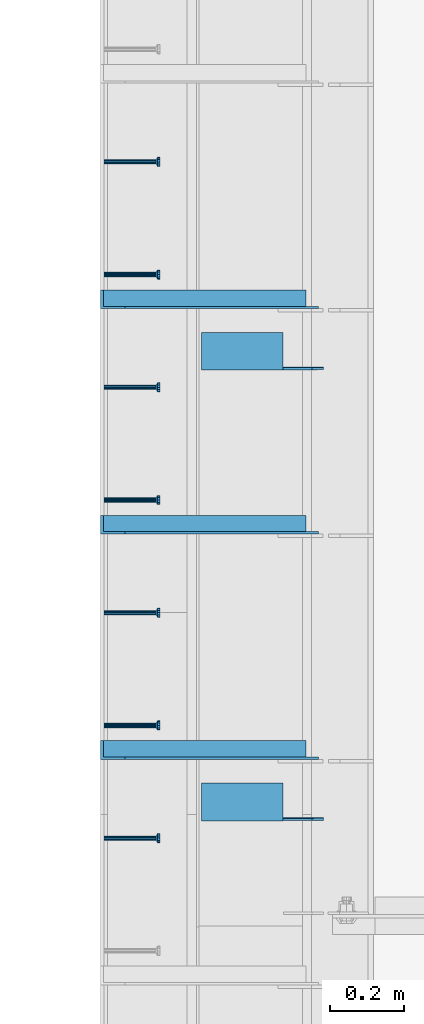
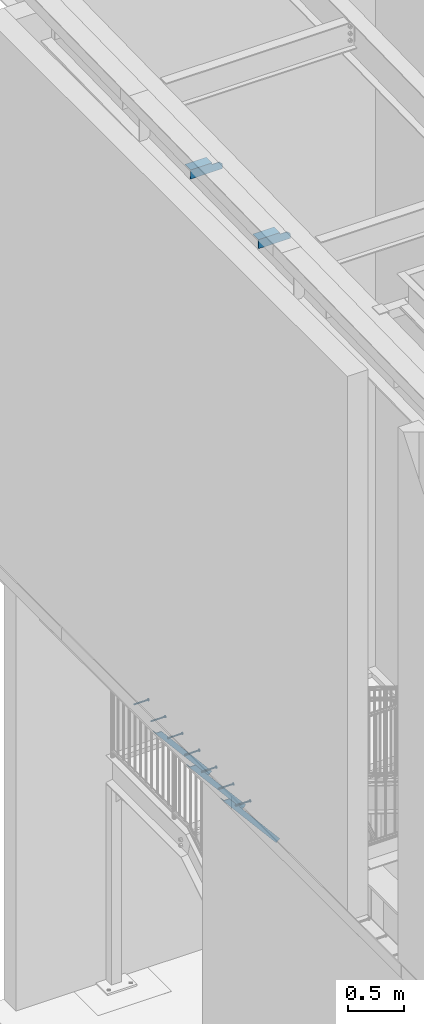
# One storey, part 1265 of 1763: 9 beams, 3 members, 9 elements without a shape of their own.
"""IFC2X3 building model written with IfcOpenShell, lengths in millimetres."""

import ifcopenshell
import ifcopenshell.guid

model = None  # the IFC model being written
_history = None  # IfcOwnerHistory: only IFC2X3 demands one
_inside = {}  # id of a spatial element -> (the spatial element, [elements in it])
_under = {}  # id of a project, library or spatial element -> (it, [spatial elements below it])
_declared = {}  # id of a project -> (the project, [libraries it declares])
_typed = {}  # id of a type object -> (the type object, [elements of that type])
_made_of = {}  # id of a material, layer set ... -> (it, [elements and type objects made of it])


def new_model(schema):
    """Start an empty IFC model of exactly this schema.

    Asked for "IFC4X3", IfcOpenShell would pick the latest addendum, in which some entities
    have other attributes; the version numbers below select the first issue.
    IFC2X3 requires an IfcOwnerHistory on every rooted entity: one is made here for all.
    """
    global model, _history
    if schema == "IFC4X3":
        model = ifcopenshell.file(schema_version=(4, 3, 0, 0))
    else:
        model = ifcopenshell.file(schema=schema)
    _inside.clear()
    _under.clear()
    _declared.clear()
    _typed.clear()
    _made_of.clear()
    _history = None
    if model.schema == "IFC2X3":
        org = make("IfcOrganization", Name="unknown")
        user = make(
            "IfcPersonAndOrganization",
            ThePerson=make("IfcPerson", FamilyName="unknown"),
            TheOrganization=org,
        )
        app = make(
            "IfcApplication",
            ApplicationDeveloper=org,
            Version="unknown",
            ApplicationFullName="unknown",
            ApplicationIdentifier="unknown",
        )
        _history = make(
            "IfcOwnerHistory",
            OwningUser=user,
            OwningApplication=app,
            ChangeAction="ADDED",
            CreationDate=0,
        )
    return model


def make(cls, **values):
    """One entity of the class cls with the attributes given. An attribute that is None is left unset."""
    return model.create_entity(
        cls, **{name: value for name, value in values.items() if value is not None}
    )


def rooted(cls, **values):
    """An entity with a GlobalId (a new one), such as an element, a storey or a relation."""
    return make(cls, GlobalId=ifcopenshell.guid.new(), OwnerHistory=_history, **values)


def si_unit(unit_type, name, prefix=None):
    """IfcSIUnit, for example si_unit("LENGTHUNIT", "METRE", prefix="MILLI")."""
    return make("IfcSIUnit", UnitType=unit_type, Prefix=prefix, Name=name)


def assignment(units):
    """IfcUnitAssignment: the units of a project."""
    return None if units is None else make("IfcUnitAssignment", Units=units)


def point(xyz):
    """IfcCartesianPoint."""
    return None if xyz is None else make("IfcCartesianPoint", Coordinates=xyz)


def direction(xyz):
    """IfcDirection."""
    return None if xyz is None else make("IfcDirection", DirectionRatios=xyz)


def frame(location, z_axis=None, x_axis=None):
    """IfcAxis2Placement3D, a coordinate frame: its origin and axes. An axis left out is left unset."""
    return make(
        "IfcAxis2Placement3D",
        Location=point(location),
        Axis=direction(z_axis),
        RefDirection=direction(x_axis),
    )


def origin_with_axes():
    """The frame at (0, 0, 0) with the z axis (0, 0, 1) and the x axis (1, 0, 0) written out."""
    return frame((0.0, 0.0, 0.0), z_axis=(0.0, 0.0, 1.0), x_axis=(1.0, 0.0, 0.0))


def place(relative_to, where):
    """IfcLocalPlacement: puts the frame where relative to a parent placement (None: the world)."""
    return make(
        "IfcLocalPlacement", PlacementRelTo=relative_to, RelativePlacement=where
    )


def context(
    kind, dimensions, precision=None, world=None, true_north=None, identifier=None
):
    """IfcGeometricRepresentationContext, for example the 3D "Model" context."""
    return make(
        "IfcGeometricRepresentationContext",
        ContextIdentifier=identifier,
        ContextType=kind,
        CoordinateSpaceDimension=dimensions,
        Precision=precision,
        WorldCoordinateSystem=world,
        TrueNorth=true_north,
    )


def subcontext(parent, identifier, kind, view, scale=None):
    """IfcGeometricRepresentationSubContext, for example "Body" below "Model"."""
    return make(
        "IfcGeometricRepresentationSubContext",
        ContextIdentifier=identifier,
        ContextType=kind,
        ParentContext=parent,
        TargetScale=scale,
        TargetView=view,
    )


def project(units=None, contexts=None):
    """IfcProject with its units and contexts."""
    return rooted(
        "IfcProject",
        Name="project",
        RepresentationContexts=contexts,
        UnitsInContext=assignment(units),
    )


def spatial(cls, under=None, at=None, **own):
    """A site, building, storey or space (cls), placed at a placement, below another one or the project."""
    s = rooted(cls, ObjectPlacement=at, **own)
    if under is not None:
        _under.setdefault(under.id(), (under, []))[1].append(s)
    return s


def faces_of(points, faces, orient=None, outer=None):
    """IfcFace entities. A face is a list of loops; a loop is a list of indices into points, from 0.

    orient and outer hold one flag for each loop. By default every Orientation is true, the
    first loop of a face is its IfcFaceOuterBound and the others are IfcFaceBound.
    """
    made = []
    for i, loops in enumerate(faces):
        bounds = []
        for j, loop in enumerate(loops):
            is_outer = j == 0 if outer is None else outer[i][j]
            bounds.append(
                make(
                    "IfcFaceOuterBound" if is_outer else "IfcFaceBound",
                    Bound=make("IfcPolyLoop", Polygon=[points[k] for k in loop]),
                    Orientation=True if orient is None else orient[i][j],
                )
            )
        made.append(make("IfcFace", Bounds=bounds))
    return made


def faceted_brep(points, faces, orient=None, outer=None, voids=None):
    """IfcFacetedBrep: a solid bounded by flat faces; with voids (closed shells), ...WithVoids."""
    shared = [point(p) for p in points]
    hull = make("IfcClosedShell", CfsFaces=faces_of(shared, faces, orient, outer))
    if voids is None:
        return make("IfcFacetedBrep", Outer=hull)
    return make(
        "IfcFacetedBrepWithVoids",
        Outer=hull,
        Voids=[
            make(cls, CfsFaces=faces_of(shared, fs, o, b)) for cls, fs, o, b in voids
        ],
    )


def shape(context_of_items, identifier, shape_type, items):
    """IfcShapeRepresentation: the items that make up one representation, for example the "Body"."""
    return make(
        "IfcShapeRepresentation",
        ContextOfItems=context_of_items,
        RepresentationIdentifier=identifier,
        RepresentationType=shape_type,
        Items=items,
    )


def material(Name=None, Category=None):
    """IfcMaterial."""
    return make("IfcMaterial", Name=Name, Category=Category)


def made_of(thing, what):
    """Note that an element or type object is made of a material, layer set ...; save() writes the relation."""
    if what is not None:
        _made_of.setdefault(what.id(), (what, []))[1].append(thing)
    return thing


def type_object(cls, material=None, **own):
    """A type object (cls), such as IfcWallType, which elements share."""
    return made_of(rooted(cls, **own), material)


def element(
    cls,
    number,
    at=None,
    inside=None,
    cuts=None,
    type_object=None,
    material=None,
    context=None,
    identifier="Body",
    shape_type=None,
    held_by="IfcProductDefinitionShape",
    body=None,
    shapes=None,
    **own,
):
    """One element of the class cls, such as IfcWall. Its Tag is "e" and its number.

    at: its placement. inside: the storey or other place that contains it. cuts: it is an
    opening in that element (IfcRelVoidsElement). A single representation is given by context,
    identifier, shape_type and body (its items); several are given by shapes. held_by: the class
    of the entity that holds the representations. save() writes the other relations.
    """
    e = rooted(cls, Tag="e%d" % number, ObjectPlacement=at, **own)
    if body is not None:
        shapes = [shape(context, identifier, shape_type, body)]
    if shapes is not None:
        e.Representation = make(held_by, Representations=shapes)
    if inside is not None:
        _inside.setdefault(inside.id(), (inside, []))[1].append(e)
    if cuts is not None:
        rooted(
            "IfcRelVoidsElement", RelatingBuildingElement=cuts, RelatedOpeningElement=e
        )
    if type_object is not None:
        _typed.setdefault(type_object.id(), (type_object, []))[1].append(e)
    return made_of(e, material)


def aggregate(whole, parts):
    """IfcRelAggregates: a whole, such as a stair, and the parts it consists of."""
    return rooted("IfcRelAggregates", RelatingObject=whole, RelatedObjects=parts)


def save(model, path):
    """Write the relations noted so far, then the file.

    IfcRelAggregates (storeys below a building ...), IfcRelContainedInSpatialStructure (elements
    in a storey), IfcRelDefinesByType, IfcRelAssociatesMaterial and IfcRelDeclares: one each for
    every whole, place, type object, material and project.
    """
    for whole, parts in _under.values():
        aggregate(whole, parts)
    for where, things in _inside.values():
        rooted(
            "IfcRelContainedInSpatialStructure",
            RelatedElements=things,
            RelatingStructure=where,
        )
    for kind, things in _typed.values():
        rooted("IfcRelDefinesByType", RelatedObjects=things, RelatingType=kind)
    for what, things in _made_of.values():
        rooted("IfcRelAssociatesMaterial", RelatedObjects=things, RelatingMaterial=what)
    for by, libraries in _declared.values():
        rooted("IfcRelDeclares", RelatingContext=by, RelatedDefinitions=libraries)
    model.write(path)


model = new_model("IFC2X3")

# Units and contexts
model_context = context("Model", 3, precision=1e-05, world=origin_with_axes())
body_context = subcontext(model_context, "Body", "Model", "MODEL_VIEW")
ifc_project = project(units=[si_unit("LENGTHUNIT", "METRE", prefix="MILLI"), si_unit("AREAUNIT", "SQUARE_METRE"), si_unit("VOLUMEUNIT", "CUBIC_METRE"), si_unit("MASSUNIT", "GRAM", prefix="KILO"), si_unit("TIMEUNIT", "SECOND"), si_unit("PLANEANGLEUNIT", "RADIAN"), si_unit("SOLIDANGLEUNIT", "STERADIAN"), si_unit("THERMODYNAMICTEMPERATUREUNIT", "DEGREE_CELSIUS"), si_unit("LUMINOUSINTENSITYUNIT", "LUMEN")], contexts=[model_context])

# Site, building, storey
site_placement = place(None, origin_with_axes())
site = spatial("IfcSite", under=ifc_project, at=site_placement, CompositionType="ELEMENT")
building_placement = place(site_placement, origin_with_axes())
building = spatial("IfcBuilding", under=site, at=building_placement, Name="Undefined", CompositionType="ELEMENT")
storey_placement = place(building_placement, origin_with_axes())
storey = spatial("IfcBuildingStorey", under=building, at=storey_placement, Name="Undefined", CompositionType="ELEMENT", Elevation=0.0)

# Assembly, beam
assembly_1_placement = place(storey_placement, origin_with_axes())
assembly_1 = element("IfcElementAssembly", 1, at=assembly_1_placement, inside=storey, Name="HEADED STUD ANCHOR", AssemblyPlace="NOTDEFINED", PredefinedType="RIGID_FRAME")
ifc_material_1 = material(Name="STEEL/A108")
beam_type_1 = type_object("IfcBeamType", PredefinedType="NOTDEFINED")
beam_1_placement = place(assembly_1_placement, frame((-87975.5122736983, 33010.4750061035, 5268.91250001202), z_axis=(0.0, 0.0, -1.0), x_axis=(1.0, 0.0, 0.0)))
beam_1 = element("IfcBeam", 2, at=beam_1_placement, type_object=beam_type_1, material=ifc_material_1, Name="HEADED STUD ANCHOR", context=body_context, shape_type="Brep", body=[
    faceted_brep([(0.0, -3.1800000667572, 5.5), (0.0, -5.5, 3.1800000667572), (141.732000000002, -5.5, 3.1800000667572), (141.732000000002, -3.1800000667572, 5.5), (0.0, -6.34999999999491, 1.45519152283669e-11), (141.732000000002, -6.34999990463257, 0.0), (0.0, -5.5, -3.1800000667572), (141.732000000002, -5.5, -3.1800000667572), (0.0, -3.1800000667572, -5.5), (141.732000000002, -3.1800000667572, -5.5), (0.0, 0.0, -6.34999990463257), (141.732000000002, 0.0, -6.34999990463257), (0.0, 3.1800000667572, -5.5), (141.732000000002, 3.1800000667572, -5.5), (0.0, 5.5, -3.1800000667572), (141.732000000002, 5.5, -3.1800000667572), (0.0, 6.34999999999491, -2.91038304567337e-11), (141.732000000002, 6.34999990463257, 0.0), (0.0, 5.5, 3.1800000667572), (141.732000000002, 5.5, 3.1800000667572), (0.0, 3.1800000667572, 5.5), (141.732000000002, 3.1800000667572, 5.5), (0.0, 0.0, 6.34999990463257), (141.732000000002, 0.0, 6.34999990463257), (144.780000000001, -10.9899997711182, 6.34999990463257), (144.780000000001, -6.34000015258789, 10.9899997711182), (144.780000000001, -12.6999998092651, 0.0), (144.780000000001, -10.9899997711182, -6.34999990463257), (144.780000000001, -6.34000015258789, -10.9899997711182), (144.780000000001, 0.0, -12.6899995803833), (144.780000000001, 6.34000015258789, -10.9899997711182), (144.780000000001, 10.9899997711182, -6.34999990463257), (144.780000000001, 12.6999998092651, 0.0), (144.780000000001, 10.9899997711182, 6.34999990463257), (144.780000000001, 6.34000015258789, 10.9899997711182), (144.780000000001, 0.0, 12.6899995803833), (152.400000000001, -10.9899997711182, 6.34999990463257), (152.400000000001, -6.34000015258789, 10.9899997711182), (152.400000000001, -12.6999998092651, 0.0), (152.400000000001, -10.9899997711182, -6.34999990463257), (152.400000000001, -6.34000015258789, -10.9899997711182), (152.400000000001, 0.0, -12.6899995803833), (152.400000000001, 6.34000015258789, -10.9899997711182), (152.400000000001, 10.9899997711182, -6.34999990463257), (152.400000000001, 12.6999998092651, 0.0), (152.400000000001, 10.9899997711182, 6.34999990463257), (152.400000000001, 6.34000015258789, 10.9899997711182), (152.400000000001, 0.0, 12.6899995803833)], [[[0, 1, 2, 3]], [[1, 4, 5, 2]], [[4, 6, 7, 5]], [[6, 8, 9, 7]], [[8, 10, 11, 9]], [[10, 12, 13, 11]], [[12, 14, 15, 13]], [[14, 16, 17, 15]], [[16, 18, 19, 17]], [[18, 20, 21, 19]], [[20, 22, 23, 21]], [[22, 0, 3, 23]], [[22, 20, 18, 16, 14, 12, 10, 8, 6, 4, 1, 0]], [[3, 2, 24, 25]], [[2, 5, 26, 24]], [[5, 7, 27, 26]], [[7, 9, 28, 27]], [[9, 11, 29, 28]], [[11, 13, 30, 29]], [[13, 15, 31, 30]], [[15, 17, 32, 31]], [[17, 19, 33, 32]], [[19, 21, 34, 33]], [[21, 23, 35, 34]], [[23, 3, 25, 35]], [[25, 24, 36, 37]], [[24, 26, 38, 36]], [[26, 27, 39, 38]], [[27, 28, 40, 39]], [[28, 29, 41, 40]], [[29, 30, 42, 41]], [[30, 31, 43, 42]], [[31, 32, 44, 43]], [[32, 33, 45, 44]], [[33, 34, 46, 45]], [[34, 35, 47, 46]], [[35, 25, 37, 47]], [[38, 39, 40, 41, 42, 43, 44, 45, 46, 47, 37, 36]]]),
])
aggregate(assembly_1, [beam_1])

assembly_2_placement = place(storey_placement, origin_with_axes())
assembly_2 = element("IfcElementAssembly", 3, at=assembly_2_placement, inside=storey, Name="HEADED STUD ANCHOR", AssemblyPlace="NOTDEFINED", PredefinedType="RIGID_FRAME")
beam_2_placement = place(assembly_2_placement, frame((-87975.5122736983, 33315.2750061035, 5268.91250001202), z_axis=(0.0, 0.0, -1.0), x_axis=(1.0, 0.0, 0.0)))
beam_2 = element("IfcBeam", 4, at=beam_2_placement, type_object=beam_type_1, material=ifc_material_1, Name="HEADED STUD ANCHOR", context=body_context, shape_type="Brep", body=[
    faceted_brep([(0.0, -3.1800000667572, 5.5), (0.0, -5.5, 3.1800000667572), (141.732000000002, -5.5, 3.1800000667572), (141.732000000002, -3.1800000667572, 5.5), (0.0, -6.34999999999491, 1.45519152283669e-11), (141.732000000002, -6.34999990463257, 0.0), (0.0, -5.5, -3.1800000667572), (141.732000000002, -5.5, -3.1800000667572), (0.0, -3.1800000667572, -5.5), (141.732000000002, -3.1800000667572, -5.5), (0.0, 0.0, -6.34999990463257), (141.732000000002, 0.0, -6.34999990463257), (0.0, 3.1800000667572, -5.5), (141.732000000002, 3.1800000667572, -5.5), (0.0, 5.5, -3.1800000667572), (141.732000000002, 5.5, -3.1800000667572), (0.0, 6.34999999999491, -2.91038304567337e-11), (141.732000000002, 6.34999990463257, 0.0), (0.0, 5.5, 3.1800000667572), (141.732000000002, 5.5, 3.1800000667572), (0.0, 3.1800000667572, 5.5), (141.732000000002, 3.1800000667572, 5.5), (0.0, 0.0, 6.34999990463257), (141.732000000002, 0.0, 6.34999990463257), (144.780000000001, -10.9899997711182, 6.34999990463257), (144.780000000001, -6.34000015258789, 10.9899997711182), (144.780000000001, -12.6999998092651, 0.0), (144.780000000001, -10.9899997711182, -6.34999990463257), (144.780000000001, -6.34000015258789, -10.9899997711182), (144.780000000001, 0.0, -12.6899995803833), (144.780000000001, 6.34000015258789, -10.9899997711182), (144.780000000001, 10.9899997711182, -6.34999990463257), (144.780000000001, 12.6999998092651, 0.0), (144.780000000001, 10.9899997711182, 6.34999990463257), (144.780000000001, 6.34000015258789, 10.9899997711182), (144.780000000001, 0.0, 12.6899995803833), (152.400000000001, -10.9899997711182, 6.34999990463257), (152.400000000001, -6.34000015258789, 10.9899997711182), (152.400000000001, -12.6999998092651, 0.0), (152.400000000001, -10.9899997711182, -6.34999990463257), (152.400000000001, -6.34000015258789, -10.9899997711182), (152.400000000001, 0.0, -12.6899995803833), (152.400000000001, 6.34000015258789, -10.9899997711182), (152.400000000001, 10.9899997711182, -6.34999990463257), (152.400000000001, 12.6999998092651, 0.0), (152.400000000001, 10.9899997711182, 6.34999990463257), (152.400000000001, 6.34000015258789, 10.9899997711182), (152.400000000001, 0.0, 12.6899995803833)], [[[0, 1, 2, 3]], [[1, 4, 5, 2]], [[4, 6, 7, 5]], [[6, 8, 9, 7]], [[8, 10, 11, 9]], [[10, 12, 13, 11]], [[12, 14, 15, 13]], [[14, 16, 17, 15]], [[16, 18, 19, 17]], [[18, 20, 21, 19]], [[20, 22, 23, 21]], [[22, 0, 3, 23]], [[22, 20, 18, 16, 14, 12, 10, 8, 6, 4, 1, 0]], [[3, 2, 24, 25]], [[2, 5, 26, 24]], [[5, 7, 27, 26]], [[7, 9, 28, 27]], [[9, 11, 29, 28]], [[11, 13, 30, 29]], [[13, 15, 31, 30]], [[15, 17, 32, 31]], [[17, 19, 33, 32]], [[19, 21, 34, 33]], [[21, 23, 35, 34]], [[23, 3, 25, 35]], [[25, 24, 36, 37]], [[24, 26, 38, 36]], [[26, 27, 39, 38]], [[27, 28, 40, 39]], [[28, 29, 41, 40]], [[29, 30, 42, 41]], [[30, 31, 43, 42]], [[31, 32, 44, 43]], [[32, 33, 45, 44]], [[33, 34, 46, 45]], [[34, 35, 47, 46]], [[35, 25, 37, 47]], [[38, 39, 40, 41, 42, 43, 44, 45, 46, 47, 37, 36]]]),
])
aggregate(assembly_2, [beam_2])

assembly_3_placement = place(storey_placement, origin_with_axes())
assembly_3 = element("IfcElementAssembly", 5, at=assembly_3_placement, inside=storey, Name="HEADED STUD ANCHOR", AssemblyPlace="NOTDEFINED", PredefinedType="RIGID_FRAME")
beam_3_placement = place(assembly_3_placement, frame((-87975.5122736983, 33620.0750061035, 5268.91250001202), z_axis=(0.0, 0.0, -1.0), x_axis=(1.0, 0.0, 0.0)))
beam_3 = element("IfcBeam", 6, at=beam_3_placement, type_object=beam_type_1, material=ifc_material_1, Name="HEADED STUD ANCHOR", context=body_context, shape_type="Brep", body=[
    faceted_brep([(0.0, -3.1800000667572, 5.5), (0.0, -5.5, 3.1800000667572), (141.732000000002, -5.5, 3.1800000667572), (141.732000000002, -3.1800000667572, 5.5), (0.0, -6.34999999999491, 1.45519152283669e-11), (141.732000000002, -6.34999990463257, 0.0), (0.0, -5.5, -3.1800000667572), (141.732000000002, -5.5, -3.1800000667572), (0.0, -3.1800000667572, -5.5), (141.732000000002, -3.1800000667572, -5.5), (0.0, 0.0, -6.34999990463257), (141.732000000002, 0.0, -6.34999990463257), (0.0, 3.1800000667572, -5.5), (141.732000000002, 3.1800000667572, -5.5), (0.0, 5.5, -3.1800000667572), (141.732000000002, 5.5, -3.1800000667572), (0.0, 6.34999999999491, -2.91038304567337e-11), (141.732000000002, 6.34999990463257, 0.0), (0.0, 5.5, 3.1800000667572), (141.732000000002, 5.5, 3.1800000667572), (0.0, 3.1800000667572, 5.5), (141.732000000002, 3.1800000667572, 5.5), (0.0, 0.0, 6.34999990463257), (141.732000000002, 0.0, 6.34999990463257), (144.780000000001, -10.9899997711182, 6.34999990463257), (144.780000000001, -6.34000015258789, 10.9899997711182), (144.780000000001, -12.6999998092651, 0.0), (144.780000000001, -10.9899997711182, -6.34999990463257), (144.780000000001, -6.34000015258789, -10.9899997711182), (144.780000000001, 0.0, -12.6899995803833), (144.780000000001, 6.34000015258789, -10.9899997711182), (144.780000000001, 10.9899997711182, -6.34999990463257), (144.780000000001, 12.6999998092651, 0.0), (144.780000000001, 10.9899997711182, 6.34999990463257), (144.780000000001, 6.34000015258789, 10.9899997711182), (144.780000000001, 0.0, 12.6899995803833), (152.400000000001, -10.9899997711182, 6.34999990463257), (152.400000000001, -6.34000015258789, 10.9899997711182), (152.400000000001, -12.6999998092651, 0.0), (152.400000000001, -10.9899997711182, -6.34999990463257), (152.400000000001, -6.34000015258789, -10.9899997711182), (152.400000000001, 0.0, -12.6899995803833), (152.400000000001, 6.34000015258789, -10.9899997711182), (152.400000000001, 10.9899997711182, -6.34999990463257), (152.400000000001, 12.6999998092651, 0.0), (152.400000000001, 10.9899997711182, 6.34999990463257), (152.400000000001, 6.34000015258789, 10.9899997711182), (152.400000000001, 0.0, 12.6899995803833)], [[[0, 1, 2, 3]], [[1, 4, 5, 2]], [[4, 6, 7, 5]], [[6, 8, 9, 7]], [[8, 10, 11, 9]], [[10, 12, 13, 11]], [[12, 14, 15, 13]], [[14, 16, 17, 15]], [[16, 18, 19, 17]], [[18, 20, 21, 19]], [[20, 22, 23, 21]], [[22, 0, 3, 23]], [[22, 20, 18, 16, 14, 12, 10, 8, 6, 4, 1, 0]], [[3, 2, 24, 25]], [[2, 5, 26, 24]], [[5, 7, 27, 26]], [[7, 9, 28, 27]], [[9, 11, 29, 28]], [[11, 13, 30, 29]], [[13, 15, 31, 30]], [[15, 17, 32, 31]], [[17, 19, 33, 32]], [[19, 21, 34, 33]], [[21, 23, 35, 34]], [[23, 3, 25, 35]], [[25, 24, 36, 37]], [[24, 26, 38, 36]], [[26, 27, 39, 38]], [[27, 28, 40, 39]], [[28, 29, 41, 40]], [[29, 30, 42, 41]], [[30, 31, 43, 42]], [[31, 32, 44, 43]], [[32, 33, 45, 44]], [[33, 34, 46, 45]], [[34, 35, 47, 46]], [[35, 25, 37, 47]], [[38, 39, 40, 41, 42, 43, 44, 45, 46, 47, 37, 36]]]),
])
aggregate(assembly_3, [beam_3])

assembly_4_placement = place(storey_placement, origin_with_axes())
assembly_4 = element("IfcElementAssembly", 7, at=assembly_4_placement, inside=storey, Name="HEADED STUD ANCHOR", AssemblyPlace="NOTDEFINED", PredefinedType="RIGID_FRAME")
beam_4_placement = place(assembly_4_placement, frame((-87975.5122736983, 33924.8750061035, 5268.91250001202), z_axis=(0.0, 0.0, -1.0), x_axis=(1.0, 0.0, 0.0)))
beam_4 = element("IfcBeam", 8, at=beam_4_placement, type_object=beam_type_1, material=ifc_material_1, Name="HEADED STUD ANCHOR", context=body_context, shape_type="Brep", body=[
    faceted_brep([(0.0, -3.1800000667572, 5.5), (0.0, -5.5, 3.1800000667572), (141.732000000002, -5.5, 3.1800000667572), (141.732000000002, -3.1800000667572, 5.5), (0.0, -6.34999999999491, 1.45519152283669e-11), (141.732000000002, -6.34999990463257, 0.0), (0.0, -5.5, -3.1800000667572), (141.732000000002, -5.5, -3.1800000667572), (0.0, -3.1800000667572, -5.5), (141.732000000002, -3.1800000667572, -5.5), (0.0, 0.0, -6.34999990463257), (141.732000000002, 0.0, -6.34999990463257), (0.0, 3.1800000667572, -5.5), (141.732000000002, 3.1800000667572, -5.5), (0.0, 5.5, -3.1800000667572), (141.732000000002, 5.5, -3.1800000667572), (0.0, 6.34999999999491, -2.91038304567337e-11), (141.732000000002, 6.34999990463257, 0.0), (0.0, 5.5, 3.1800000667572), (141.732000000002, 5.5, 3.1800000667572), (0.0, 3.1800000667572, 5.5), (141.732000000002, 3.1800000667572, 5.5), (0.0, 0.0, 6.34999990463257), (141.732000000002, 0.0, 6.34999990463257), (144.780000000001, -10.9899997711182, 6.34999990463257), (144.780000000001, -6.34000015258789, 10.9899997711182), (144.780000000001, -12.6999998092651, 0.0), (144.780000000001, -10.9899997711182, -6.34999990463257), (144.780000000001, -6.34000015258789, -10.9899997711182), (144.780000000001, 0.0, -12.6899995803833), (144.780000000001, 6.34000015258789, -10.9899997711182), (144.780000000001, 10.9899997711182, -6.34999990463257), (144.780000000001, 12.6999998092651, 0.0), (144.780000000001, 10.9899997711182, 6.34999990463257), (144.780000000001, 6.34000015258789, 10.9899997711182), (144.780000000001, 0.0, 12.6899995803833), (152.400000000001, -10.9899997711182, 6.34999990463257), (152.400000000001, -6.34000015258789, 10.9899997711182), (152.400000000001, -12.6999998092651, 0.0), (152.400000000001, -10.9899997711182, -6.34999990463257), (152.400000000001, -6.34000015258789, -10.9899997711182), (152.400000000001, 0.0, -12.6899995803833), (152.400000000001, 6.34000015258789, -10.9899997711182), (152.400000000001, 10.9899997711182, -6.34999990463257), (152.400000000001, 12.6999998092651, 0.0), (152.400000000001, 10.9899997711182, 6.34999990463257), (152.400000000001, 6.34000015258789, 10.9899997711182), (152.400000000001, 0.0, 12.6899995803833)], [[[0, 1, 2, 3]], [[1, 4, 5, 2]], [[4, 6, 7, 5]], [[6, 8, 9, 7]], [[8, 10, 11, 9]], [[10, 12, 13, 11]], [[12, 14, 15, 13]], [[14, 16, 17, 15]], [[16, 18, 19, 17]], [[18, 20, 21, 19]], [[20, 22, 23, 21]], [[22, 0, 3, 23]], [[22, 20, 18, 16, 14, 12, 10, 8, 6, 4, 1, 0]], [[3, 2, 24, 25]], [[2, 5, 26, 24]], [[5, 7, 27, 26]], [[7, 9, 28, 27]], [[9, 11, 29, 28]], [[11, 13, 30, 29]], [[13, 15, 31, 30]], [[15, 17, 32, 31]], [[17, 19, 33, 32]], [[19, 21, 34, 33]], [[21, 23, 35, 34]], [[23, 3, 25, 35]], [[25, 24, 36, 37]], [[24, 26, 38, 36]], [[26, 27, 39, 38]], [[27, 28, 40, 39]], [[28, 29, 41, 40]], [[29, 30, 42, 41]], [[30, 31, 43, 42]], [[31, 32, 44, 43]], [[32, 33, 45, 44]], [[33, 34, 46, 45]], [[34, 35, 47, 46]], [[35, 25, 37, 47]], [[38, 39, 40, 41, 42, 43, 44, 45, 46, 47, 37, 36]]]),
])
aggregate(assembly_4, [beam_4])

assembly_5_placement = place(storey_placement, origin_with_axes())
assembly_5 = element("IfcElementAssembly", 9, at=assembly_5_placement, inside=storey, Name="HEADED STUD ANCHOR", AssemblyPlace="NOTDEFINED", PredefinedType="RIGID_FRAME")
beam_5_placement = place(assembly_5_placement, frame((-87975.5122736983, 34229.6750061035, 5268.91250001202), z_axis=(0.0, 0.0, -1.0), x_axis=(1.0, 0.0, 0.0)))
beam_5 = element("IfcBeam", 10, at=beam_5_placement, type_object=beam_type_1, material=ifc_material_1, Name="HEADED STUD ANCHOR", context=body_context, shape_type="Brep", body=[
    faceted_brep([(0.0, -3.1800000667572, 5.5), (0.0, -5.5, 3.1800000667572), (141.732000000002, -5.5, 3.1800000667572), (141.732000000002, -3.1800000667572, 5.5), (0.0, -6.34999999999491, 1.45519152283669e-11), (141.732000000002, -6.34999990463257, 0.0), (0.0, -5.5, -3.1800000667572), (141.732000000002, -5.5, -3.1800000667572), (0.0, -3.1800000667572, -5.5), (141.732000000002, -3.1800000667572, -5.5), (0.0, 0.0, -6.34999990463257), (141.732000000002, 0.0, -6.34999990463257), (0.0, 3.1800000667572, -5.5), (141.732000000002, 3.1800000667572, -5.5), (0.0, 5.5, -3.1800000667572), (141.732000000002, 5.5, -3.1800000667572), (0.0, 6.34999999999491, -2.91038304567337e-11), (141.732000000002, 6.34999990463257, 0.0), (0.0, 5.5, 3.1800000667572), (141.732000000002, 5.5, 3.1800000667572), (0.0, 3.1800000667572, 5.5), (141.732000000002, 3.1800000667572, 5.5), (0.0, 0.0, 6.34999990463257), (141.732000000002, 0.0, 6.34999990463257), (144.780000000001, -10.9899997711182, 6.34999990463257), (144.780000000001, -6.34000015258789, 10.9899997711182), (144.780000000001, -12.6999998092651, 0.0), (144.780000000001, -10.9899997711182, -6.34999990463257), (144.780000000001, -6.34000015258789, -10.9899997711182), (144.780000000001, 0.0, -12.6899995803833), (144.780000000001, 6.34000015258789, -10.9899997711182), (144.780000000001, 10.9899997711182, -6.34999990463257), (144.780000000001, 12.6999998092651, 0.0), (144.780000000001, 10.9899997711182, 6.34999990463257), (144.780000000001, 6.34000015258789, 10.9899997711182), (144.780000000001, 0.0, 12.6899995803833), (152.400000000001, -10.9899997711182, 6.34999990463257), (152.400000000001, -6.34000015258789, 10.9899997711182), (152.400000000001, -12.6999998092651, 0.0), (152.400000000001, -10.9899997711182, -6.34999990463257), (152.400000000001, -6.34000015258789, -10.9899997711182), (152.400000000001, 0.0, -12.6899995803833), (152.400000000001, 6.34000015258789, -10.9899997711182), (152.400000000001, 10.9899997711182, -6.34999990463257), (152.400000000001, 12.6999998092651, 0.0), (152.400000000001, 10.9899997711182, 6.34999990463257), (152.400000000001, 6.34000015258789, 10.9899997711182), (152.400000000001, 0.0, 12.6899995803833)], [[[0, 1, 2, 3]], [[1, 4, 5, 2]], [[4, 6, 7, 5]], [[6, 8, 9, 7]], [[8, 10, 11, 9]], [[10, 12, 13, 11]], [[12, 14, 15, 13]], [[14, 16, 17, 15]], [[16, 18, 19, 17]], [[18, 20, 21, 19]], [[20, 22, 23, 21]], [[22, 0, 3, 23]], [[22, 20, 18, 16, 14, 12, 10, 8, 6, 4, 1, 0]], [[3, 2, 24, 25]], [[2, 5, 26, 24]], [[5, 7, 27, 26]], [[7, 9, 28, 27]], [[9, 11, 29, 28]], [[11, 13, 30, 29]], [[13, 15, 31, 30]], [[15, 17, 32, 31]], [[17, 19, 33, 32]], [[19, 21, 34, 33]], [[21, 23, 35, 34]], [[23, 3, 25, 35]], [[25, 24, 36, 37]], [[24, 26, 38, 36]], [[26, 27, 39, 38]], [[27, 28, 40, 39]], [[28, 29, 41, 40]], [[29, 30, 42, 41]], [[30, 31, 43, 42]], [[31, 32, 44, 43]], [[32, 33, 45, 44]], [[33, 34, 46, 45]], [[34, 35, 47, 46]], [[35, 25, 37, 47]], [[38, 39, 40, 41, 42, 43, 44, 45, 46, 47, 37, 36]]]),
])
aggregate(assembly_5, [beam_5])

assembly_6_placement = place(storey_placement, origin_with_axes())
assembly_6 = element("IfcElementAssembly", 11, at=assembly_6_placement, inside=storey, Name="HEADED STUD ANCHOR", AssemblyPlace="NOTDEFINED", PredefinedType="RIGID_FRAME")
beam_6_placement = place(assembly_6_placement, frame((-87975.5122736983, 34534.4750061035, 5268.91250001202), z_axis=(0.0, 0.0, -1.0), x_axis=(1.0, 0.0, 0.0)))
beam_6 = element("IfcBeam", 12, at=beam_6_placement, type_object=beam_type_1, material=ifc_material_1, Name="HEADED STUD ANCHOR", context=body_context, shape_type="Brep", body=[
    faceted_brep([(0.0, -3.1800000667572, 5.5), (0.0, -5.5, 3.1800000667572), (141.732000000002, -5.5, 3.1800000667572), (141.732000000002, -3.1800000667572, 5.5), (0.0, -6.34999999999491, 1.45519152283669e-11), (141.732000000002, -6.34999990463257, 0.0), (0.0, -5.5, -3.1800000667572), (141.732000000002, -5.5, -3.1800000667572), (0.0, -3.1800000667572, -5.5), (141.732000000002, -3.1800000667572, -5.5), (0.0, 0.0, -6.34999990463257), (141.732000000002, 0.0, -6.34999990463257), (0.0, 3.1800000667572, -5.5), (141.732000000002, 3.1800000667572, -5.5), (0.0, 5.5, -3.1800000667572), (141.732000000002, 5.5, -3.1800000667572), (0.0, 6.34999999999491, -2.91038304567337e-11), (141.732000000002, 6.34999990463257, 0.0), (0.0, 5.5, 3.1800000667572), (141.732000000002, 5.5, 3.1800000667572), (0.0, 3.1800000667572, 5.5), (141.732000000002, 3.1800000667572, 5.5), (0.0, 0.0, 6.34999990463257), (141.732000000002, 0.0, 6.34999990463257), (144.780000000001, -10.9899997711182, 6.34999990463257), (144.780000000001, -6.34000015258789, 10.9899997711182), (144.780000000001, -12.6999998092651, 0.0), (144.780000000001, -10.9899997711182, -6.34999990463257), (144.780000000001, -6.34000015258789, -10.9899997711182), (144.780000000001, 0.0, -12.6899995803833), (144.780000000001, 6.34000015258789, -10.9899997711182), (144.780000000001, 10.9899997711182, -6.34999990463257), (144.780000000001, 12.6999998092651, 0.0), (144.780000000001, 10.9899997711182, 6.34999990463257), (144.780000000001, 6.34000015258789, 10.9899997711182), (144.780000000001, 0.0, 12.6899995803833), (152.400000000001, -10.9899997711182, 6.34999990463257), (152.400000000001, -6.34000015258789, 10.9899997711182), (152.400000000001, -12.6999998092651, 0.0), (152.400000000001, -10.9899997711182, -6.34999990463257), (152.400000000001, -6.34000015258789, -10.9899997711182), (152.400000000001, 0.0, -12.6899995803833), (152.400000000001, 6.34000015258789, -10.9899997711182), (152.400000000001, 10.9899997711182, -6.34999990463257), (152.400000000001, 12.6999998092651, 0.0), (152.400000000001, 10.9899997711182, 6.34999990463257), (152.400000000001, 6.34000015258789, 10.9899997711182), (152.400000000001, 0.0, 12.6899995803833)], [[[0, 1, 2, 3]], [[1, 4, 5, 2]], [[4, 6, 7, 5]], [[6, 8, 9, 7]], [[8, 10, 11, 9]], [[10, 12, 13, 11]], [[12, 14, 15, 13]], [[14, 16, 17, 15]], [[16, 18, 19, 17]], [[18, 20, 21, 19]], [[20, 22, 23, 21]], [[22, 0, 3, 23]], [[22, 20, 18, 16, 14, 12, 10, 8, 6, 4, 1, 0]], [[3, 2, 24, 25]], [[2, 5, 26, 24]], [[5, 7, 27, 26]], [[7, 9, 28, 27]], [[9, 11, 29, 28]], [[11, 13, 30, 29]], [[13, 15, 31, 30]], [[15, 17, 32, 31]], [[17, 19, 33, 32]], [[19, 21, 34, 33]], [[21, 23, 35, 34]], [[23, 3, 25, 35]], [[25, 24, 36, 37]], [[24, 26, 38, 36]], [[26, 27, 39, 38]], [[27, 28, 40, 39]], [[28, 29, 41, 40]], [[29, 30, 42, 41]], [[30, 31, 43, 42]], [[31, 32, 44, 43]], [[32, 33, 45, 44]], [[33, 34, 46, 45]], [[34, 35, 47, 46]], [[35, 25, 37, 47]], [[38, 39, 40, 41, 42, 43, 44, 45, 46, 47, 37, 36]]]),
])
aggregate(assembly_6, [beam_6])

assembly_7_placement = place(storey_placement, origin_with_axes())
assembly_7 = element("IfcElementAssembly", 13, at=assembly_7_placement, inside=storey, Name="HEADED STUD ANCHOR", AssemblyPlace="NOTDEFINED", PredefinedType="RIGID_FRAME")
beam_7_placement = place(assembly_7_placement, frame((-87975.5122736983, 34839.2750061035, 5268.91250001202), z_axis=(0.0, 0.0, -1.0), x_axis=(1.0, 0.0, 0.0)))
beam_7 = element("IfcBeam", 14, at=beam_7_placement, type_object=beam_type_1, material=ifc_material_1, Name="HEADED STUD ANCHOR", context=body_context, shape_type="Brep", body=[
    faceted_brep([(0.0, -3.1800000667572, 5.5), (0.0, -5.5, 3.1800000667572), (141.732000000002, -5.5, 3.1800000667572), (141.732000000002, -3.1800000667572, 5.5), (0.0, -6.34999999999491, 1.45519152283669e-11), (141.732000000002, -6.34999990463257, 0.0), (0.0, -5.5, -3.1800000667572), (141.732000000002, -5.5, -3.1800000667572), (0.0, -3.1800000667572, -5.5), (141.732000000002, -3.1800000667572, -5.5), (0.0, 0.0, -6.34999990463257), (141.732000000002, 0.0, -6.34999990463257), (0.0, 3.1800000667572, -5.5), (141.732000000002, 3.1800000667572, -5.5), (0.0, 5.5, -3.1800000667572), (141.732000000002, 5.5, -3.1800000667572), (0.0, 6.34999999999491, -2.91038304567337e-11), (141.732000000002, 6.34999990463257, 0.0), (0.0, 5.5, 3.1800000667572), (141.732000000002, 5.5, 3.1800000667572), (0.0, 3.1800000667572, 5.5), (141.732000000002, 3.1800000667572, 5.5), (0.0, 0.0, 6.34999990463257), (141.732000000002, 0.0, 6.34999990463257), (144.780000000001, -10.9899997711182, 6.34999990463257), (144.780000000001, -6.34000015258789, 10.9899997711182), (144.780000000001, -12.6999998092651, 0.0), (144.780000000001, -10.9899997711182, -6.34999990463257), (144.780000000001, -6.34000015258789, -10.9899997711182), (144.780000000001, 0.0, -12.6899995803833), (144.780000000001, 6.34000015258789, -10.9899997711182), (144.780000000001, 10.9899997711182, -6.34999990463257), (144.780000000001, 12.6999998092651, 0.0), (144.780000000001, 10.9899997711182, 6.34999990463257), (144.780000000001, 6.34000015258789, 10.9899997711182), (144.780000000001, 0.0, 12.6899995803833), (152.400000000001, -10.9899997711182, 6.34999990463257), (152.400000000001, -6.34000015258789, 10.9899997711182), (152.400000000001, -12.6999998092651, 0.0), (152.400000000001, -10.9899997711182, -6.34999990463257), (152.400000000001, -6.34000015258789, -10.9899997711182), (152.400000000001, 0.0, -12.6899995803833), (152.400000000001, 6.34000015258789, -10.9899997711182), (152.400000000001, 10.9899997711182, -6.34999990463257), (152.400000000001, 12.6999998092651, 0.0), (152.400000000001, 10.9899997711182, 6.34999990463257), (152.400000000001, 6.34000015258789, 10.9899997711182), (152.400000000001, 0.0, 12.6899995803833)], [[[0, 1, 2, 3]], [[1, 4, 5, 2]], [[4, 6, 7, 5]], [[6, 8, 9, 7]], [[8, 10, 11, 9]], [[10, 12, 13, 11]], [[12, 14, 15, 13]], [[14, 16, 17, 15]], [[16, 18, 19, 17]], [[18, 20, 21, 19]], [[20, 22, 23, 21]], [[22, 0, 3, 23]], [[22, 20, 18, 16, 14, 12, 10, 8, 6, 4, 1, 0]], [[3, 2, 24, 25]], [[2, 5, 26, 24]], [[5, 7, 27, 26]], [[7, 9, 28, 27]], [[9, 11, 29, 28]], [[11, 13, 30, 29]], [[13, 15, 31, 30]], [[15, 17, 32, 31]], [[17, 19, 33, 32]], [[19, 21, 34, 33]], [[21, 23, 35, 34]], [[23, 3, 25, 35]], [[25, 24, 36, 37]], [[24, 26, 38, 36]], [[26, 27, 39, 38]], [[27, 28, 40, 39]], [[28, 29, 41, 40]], [[29, 30, 42, 41]], [[30, 31, 43, 42]], [[31, 32, 44, 43]], [[32, 33, 45, 44]], [[33, 34, 46, 45]], [[34, 35, 47, 46]], [[35, 25, 37, 47]], [[38, 39, 40, 41, 42, 43, 44, 45, 46, 47, 37, 36]]]),
])
aggregate(assembly_7, [beam_7])

# Assembly, members
assembly_8_placement = place(storey_placement, origin_with_axes())
assembly_8 = element("IfcElementAssembly", 15, at=assembly_8_placement, inside=storey, Name="BEAM", AssemblyPlace="NOTDEFINED", PredefinedType="RIGID_FRAME")
ifc_material_2 = material(Name="STEEL/A36")
member_type = type_object("IfcMemberType", Name="L2X2X1/4", PredefinedType="NOTDEFINED")
member_1_placement = place(assembly_8_placement, frame((-87414.1929584935, 33858.2, 4557.35349338836), z_axis=(0.764183480307171, 0.0, 0.644998921259268), x_axis=(-0.644998921259266, 0.0, 0.764183480307173)))
member_1 = element("IfcMember", 16, at=member_1_placement, type_object=member_type, material=ifc_material_2, Name="ANGLE", ObjectType="L2X2X1/4", context=body_context, shape_type="Brep", body=[
    faceted_brep([(-1.45519152283669e-11, 25.4000000000015, -25.3999999999869), (1.45519152283669e-11, 25.4000000000015, 25.3999999999796), (812.060911532491, 25.4000000000015, 25.400000001966), (854.937976763787, 25.4000000000015, -25.3999999979424), (1.45519152283669e-11, 19.0499999999993, 25.3999999999796), (812.060911532491, 19.0500000000029, 25.400000001966), (-7.27595761418343e-12, 19.0499999999993, -19.0499999999956), (849.578343609872, 19.0500000000029, -19.0499999979511), (-7.27595761418343e-12, -25.4000000000015, -19.0499999999956), (849.578343609872, -25.4000000000015, -19.0499999979511), (-1.45519152283669e-11, -25.4000000000015, -25.3999999999869), (854.937976763787, -25.4000000000015, -25.3999999979424)], [[[0, 1, 2, 3]], [[1, 4, 5, 2]], [[4, 6, 7, 5]], [[6, 8, 9, 7]], [[8, 10, 11, 9]], [[10, 0, 3, 11]], [[5, 7, 9, 11, 3, 2]], [[10, 8, 6, 4, 1, 0]]]),
])
member_2_placement = place(assembly_8_placement, frame((-87414.1929584935, 33248.6, 4557.35349338836), z_axis=(0.764183480307171, 0.0, 0.644998921259268), x_axis=(-0.644998921259266, 0.0, 0.764183480307173)))
member_2 = element("IfcMember", 17, at=member_2_placement, type_object=member_type, material=ifc_material_2, Name="ANGLE", ObjectType="L2X2X1/4", context=body_context, shape_type="Brep", body=[
    faceted_brep([(-1.45519152283669e-11, 25.4000000000015, -25.3999999999869), (1.45519152283669e-11, 25.4000000000015, 25.3999999999796), (812.060911532491, 25.4000000000015, 25.400000001966), (854.937976763787, 25.4000000000015, -25.3999999979424), (1.45519152283669e-11, 19.0499999999993, 25.3999999999796), (812.060911532491, 19.0500000000029, 25.400000001966), (-7.27595761418343e-12, 19.0499999999993, -19.0499999999956), (849.578343609872, 19.0500000000029, -19.0499999979511), (-7.27595761418343e-12, -25.4000000000015, -19.0499999999956), (849.578343609872, -25.4000000000015, -19.0499999979511), (-1.45519152283669e-11, -25.4000000000015, -25.3999999999869), (854.937976763787, -25.4000000000015, -25.3999999979424)], [[[0, 1, 2, 3]], [[1, 4, 5, 2]], [[4, 6, 7, 5]], [[6, 8, 9, 7]], [[8, 10, 11, 9]], [[10, 0, 3, 11]], [[5, 7, 9, 11, 3, 2]], [[10, 8, 6, 4, 1, 0]]]),
])
member_3_placement = place(assembly_8_placement, frame((-87414.1929584935, 34467.8, 4557.35349338836), z_axis=(0.764183480307171, 0.0, 0.644998921259268), x_axis=(-0.644998921259266, 0.0, 0.764183480307173)))
member_3 = element("IfcMember", 18, at=member_3_placement, type_object=member_type, material=ifc_material_2, Name="ANGLE", ObjectType="L2X2X1/4", context=body_context, shape_type="Brep", body=[
    faceted_brep([(-1.45519152283669e-11, 25.4000000000015, -25.3999999999869), (1.45519152283669e-11, 25.4000000000015, 25.3999999999796), (812.060911532491, 25.4000000000015, 25.400000001966), (854.937976763787, 25.4000000000015, -25.3999999979424), (1.45519152283669e-11, 19.0499999999993, 25.3999999999796), (812.060911532491, 19.0500000000029, 25.400000001966), (-7.27595761418343e-12, 19.0499999999993, -19.0499999999956), (849.578343609872, 19.0500000000029, -19.0499999979511), (-7.27595761418343e-12, -25.4000000000015, -19.0499999999956), (849.578343609872, -25.4000000000015, -19.0499999979511), (-1.45519152283669e-11, -25.4000000000015, -25.3999999999869), (854.937976763787, -25.4000000000015, -25.3999999979424)], [[[0, 1, 2, 3]], [[1, 4, 5, 2]], [[4, 6, 7, 5]], [[6, 8, 9, 7]], [[8, 10, 11, 9]], [[10, 0, 3, 11]], [[5, 7, 9, 11, 3, 2]], [[10, 8, 6, 4, 1, 0]]]),
])
aggregate(assembly_8, [member_1, member_2, member_3])

# Assembly, beams
assembly_9_placement = place(storey_placement, origin_with_axes())
assembly_9 = element("IfcElementAssembly", 19, at=assembly_9_placement, inside=storey, Name="BEAM", AssemblyPlace="NOTDEFINED", PredefinedType="RIGID_FRAME")
beam_type_2 = type_object("IfcBeamType", Name="L4X4X1/4", PredefinedType="NOTDEFINED")
beam_8_placement = place(assembly_9_placement, frame((-87711.9872706466, 34328.2545814052, 11328.5674974319), z_axis=(0.0, 0.0206852279954837, -0.999786037781472), x_axis=(1.0, 0.0, 0.0)))
beam_8 = element("IfcBeam", 20, at=beam_8_placement, type_object=beam_type_2, material=ifc_material_2, Name="BRACE", ObjectType="L4X4X1/4", context=body_context, shape_type="Brep", body=[
    faceted_brep([(220.662761923406, 44.4500000001208, -44.4499999999807), (220.662761962012, -50.800000000163, -44.4499999999553), (220.66276795695, -50.800000000163, -50.7999999999502), (220.662767915564, 50.8000000001339, -50.7999999999774), (220.662751535681, 50.8000000001339, -33.3786578752915), (220.662751538272, 44.4500000001208, -33.3786578752897), (299.243730570859, 44.4500000001135, -33.3375021376705), (299.243730570859, 50.8000000001339, -33.3375021376723), (2.11002770811319e-10, -50.8000000000357, -50.799999999952), (1.96450855582952e-10, -50.8000000000338, -44.4499999999534), (-2.18278728425503e-11, 44.4500000000007, -44.450000000048), (-1.81898940354586e-10, 44.4500000000371, 50.7999999999374), (-1.96450855582952e-10, 50.8000000000393, 50.7999999999374), (-3.63797880709171e-11, 50.8000000000011, -50.8000000000538), (330.993731689443, 44.4500000000007, 50.7999999999993), (330.993731689443, 50.7999999999993, 50.7999999999993), (330.993730570859, 44.4500000001281, -1.58750213774329), (330.993746948254, 50.8000000001412, -1.5875021377451)], [[[0, 1, 2, 3, 4, 5]], [[6, 5, 4, 7]], [[8, 9, 10, 11, 12, 13]], [[12, 11, 14, 15]], [[15, 14, 16, 17]], [[17, 16, 6, 7]], [[3, 13, 12, 15, 17, 7, 4]], [[8, 13, 3, 2]], [[9, 8, 2, 1]], [[10, 9, 1, 0]], [[16, 14, 11, 10, 0, 5, 6]]]),
])
beam_9_placement = place(assembly_9_placement, frame((-87711.9872706466, 33109.3154441422, 11303.3480674599), z_axis=(0.0, 0.0206852279954837, -0.999786037781472), x_axis=(1.0, 0.0, 0.0)))
beam_9 = element("IfcBeam", 21, at=beam_9_placement, type_object=beam_type_2, material=ifc_material_2, Name="BRACE", ObjectType="L4X4X1/4", context=body_context, shape_type="Brep", body=[
    faceted_brep([(220.662761923406, 44.4500000001208, -44.4499999999807), (220.662761962012, -50.800000000163, -44.4499999999553), (220.66276795695, -50.800000000163, -50.7999999999502), (220.662767915564, 50.8000000001339, -50.7999999999774), (220.662751535681, 50.8000000001339, -33.3786578752915), (220.662751538272, 44.4500000001208, -33.3786578752897), (299.243730570859, 44.4500000001135, -33.3375021376705), (299.243730570859, 50.8000000001339, -33.3375021376723), (2.11002770811319e-10, -50.8000000000357, -50.799999999952), (1.96450855582952e-10, -50.8000000000338, -44.4499999999534), (-2.18278728425503e-11, 44.4500000000007, -44.450000000048), (-1.81898940354586e-10, 44.4500000000371, 50.7999999999374), (-1.96450855582952e-10, 50.8000000000393, 50.7999999999374), (-3.63797880709171e-11, 50.8000000000011, -50.8000000000538), (330.993731689443, 44.4500000000007, 50.7999999999993), (330.993731689443, 50.7999999999993, 50.7999999999993), (330.993730570859, 44.4500000001281, -1.58750213774329), (330.993746948254, 50.8000000001412, -1.5875021377451)], [[[0, 1, 2, 3, 4, 5]], [[6, 5, 4, 7]], [[8, 9, 10, 11, 12, 13]], [[12, 11, 14, 15]], [[15, 14, 16, 17]], [[17, 16, 6, 7]], [[3, 13, 12, 15, 17, 7, 4]], [[8, 13, 3, 2]], [[9, 8, 2, 1]], [[10, 9, 1, 0]], [[16, 14, 11, 10, 0, 5, 6]]]),
])
aggregate(assembly_9, [beam_8, beam_9])

save(model, "model.ifc")
